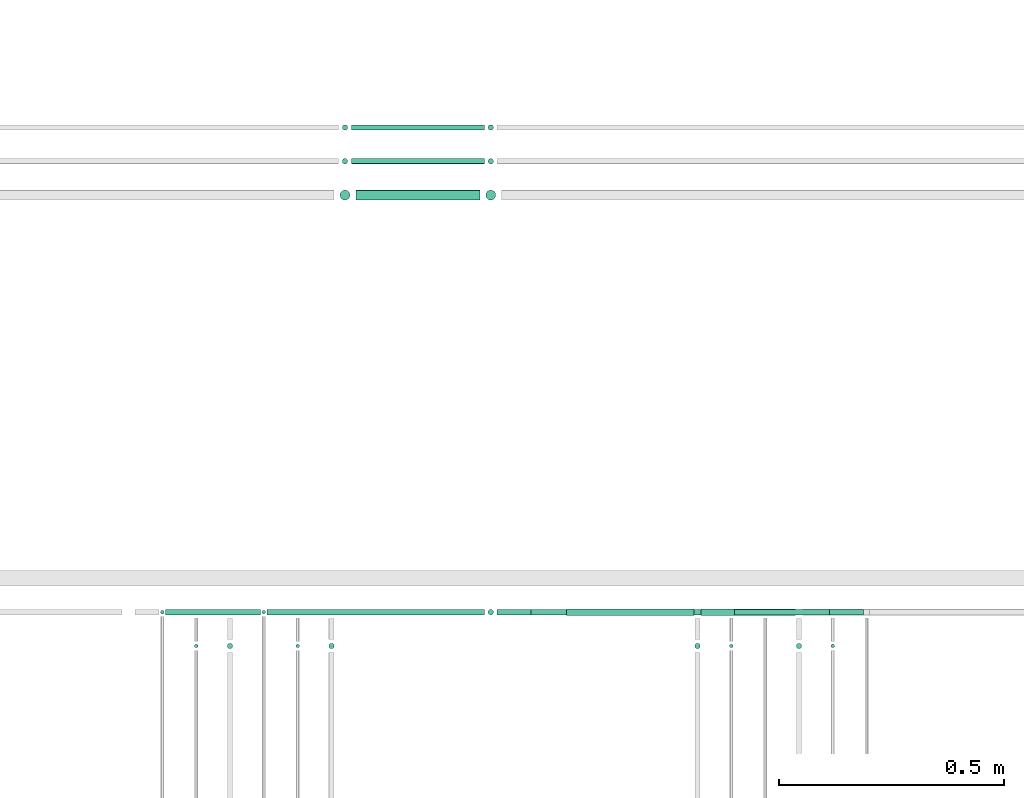
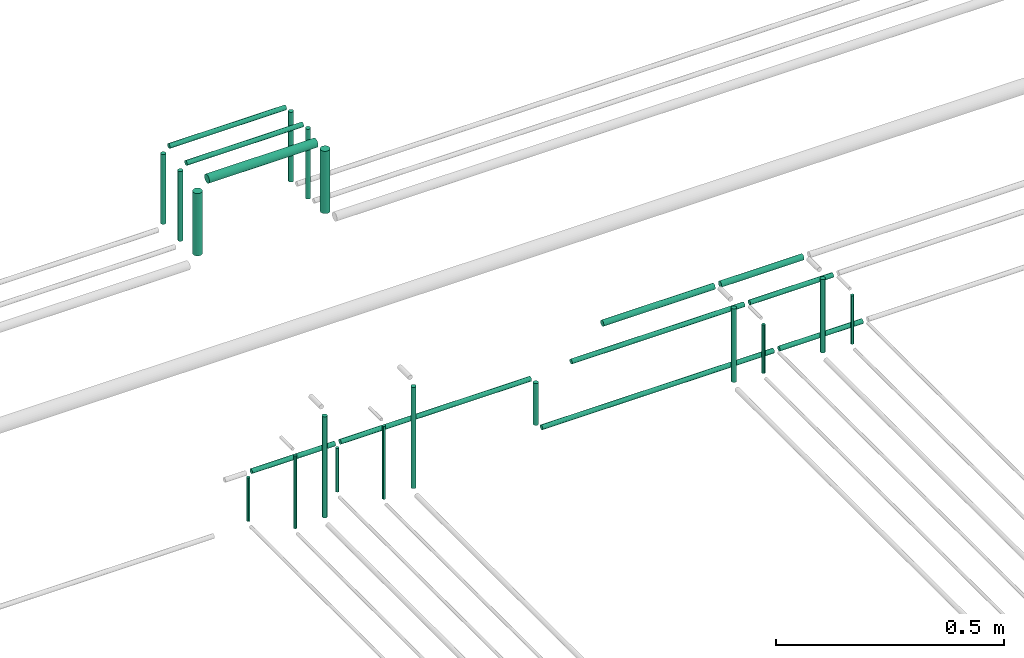
# One storey, part 142 of 331: 28 flow segments.
"""IFC2X3 building model written with IfcOpenShell, lengths in millimetres."""

from ifc_helpers import new_model, entity, si_unit, converted_unit, derived_unit, direction, frame, frame_2d, origin, origin_2d_with_axis, place, context, subcontext, project, spatial, circle, extrude, type_object, element, save


model = new_model("IFC2X3")

# Units and contexts
model_context = context("Model", 3, precision=0.01, world=origin(), true_north=direction((6.12303176911189e-17, 1.0)))
body_context = subcontext(model_context, "Body", "Model", "MODEL_VIEW")
ifc_project = project(units=[si_unit("LENGTHUNIT", "METRE", prefix="MILLI"), si_unit("AREAUNIT", "SQUARE_METRE"), si_unit("VOLUMEUNIT", "CUBIC_METRE"), converted_unit("PLANEANGLEUNIT", "DEGREE", entity("IfcRatioMeasure", 0.0174532925199433), si_unit("PLANEANGLEUNIT", "RADIAN"), dimensions=[0, 0, 0, 0, 0, 0, 0]), si_unit("MASSUNIT", "GRAM", prefix="KILO"), derived_unit("MASSDENSITYUNIT", [(si_unit("MASSUNIT", "GRAM", prefix="KILO"), 1), (si_unit("LENGTHUNIT", "METRE"), -3)]), derived_unit("MOMENTOFINERTIAUNIT", [(si_unit("LENGTHUNIT", "METRE"), 4)]), si_unit("TIMEUNIT", "SECOND"), si_unit("FREQUENCYUNIT", "HERTZ"), si_unit("THERMODYNAMICTEMPERATUREUNIT", "DEGREE_CELSIUS"), derived_unit("THERMALTRANSMITTANCEUNIT", [(si_unit("MASSUNIT", "GRAM", prefix="KILO"), 1), (si_unit("THERMODYNAMICTEMPERATUREUNIT", "KELVIN"), -1), (si_unit("TIMEUNIT", "SECOND"), -3)]), derived_unit("VOLUMETRICFLOWRATEUNIT", [(si_unit("LENGTHUNIT", "METRE"), 3), (si_unit("TIMEUNIT", "SECOND"), -1)]), derived_unit("MASSFLOWRATEUNIT", [(si_unit("MASSUNIT", "GRAM", prefix="KILO"), 1), (si_unit("TIMEUNIT", "SECOND"), -1)]), derived_unit("ROTATIONALFREQUENCYUNIT", [(si_unit("TIMEUNIT", "SECOND"), -1)]), si_unit("ELECTRICCURRENTUNIT", "AMPERE"), si_unit("ELECTRICVOLTAGEUNIT", "VOLT"), si_unit("POWERUNIT", "WATT"), si_unit("FORCEUNIT", "NEWTON", prefix="KILO"), si_unit("ILLUMINANCEUNIT", "LUX"), si_unit("LUMINOUSFLUXUNIT", "LUMEN"), si_unit("LUMINOUSINTENSITYUNIT", "CANDELA"), derived_unit("USERDEFINED", [(si_unit("MASSUNIT", "GRAM", prefix="KILO"), -1), (si_unit("LENGTHUNIT", "METRE"), -2), (si_unit("TIMEUNIT", "SECOND"), 3), (si_unit("LUMINOUSFLUXUNIT", "LUMEN"), 1)]), derived_unit("LINEARVELOCITYUNIT", [(si_unit("LENGTHUNIT", "METRE"), 1), (si_unit("TIMEUNIT", "SECOND"), -1)]), si_unit("PRESSUREUNIT", "PASCAL"), derived_unit("USERDEFINED", [(si_unit("LENGTHUNIT", "METRE"), -2), (si_unit("MASSUNIT", "GRAM", prefix="KILO"), 1), (si_unit("TIMEUNIT", "SECOND"), -2)]), derived_unit("LINEARFORCEUNIT", [(si_unit("MASSUNIT", "GRAM", prefix="KILO"), 1), (si_unit("LENGTHUNIT", "METRE"), 1), (si_unit("TIMEUNIT", "SECOND"), -2), (si_unit("LENGTHUNIT", "METRE"), -1)]), derived_unit("PLANARFORCEUNIT", [(si_unit("MASSUNIT", "GRAM", prefix="KILO"), 1), (si_unit("LENGTHUNIT", "METRE"), 1), (si_unit("TIMEUNIT", "SECOND"), -2), (si_unit("LENGTHUNIT", "METRE"), -2)])], contexts=[model_context])

# Site, building, storey
site_placement = place(None, frame((0.0, -0.00077364408347762, 0.0)))
site = spatial("IfcSite", under=ifc_project, at=site_placement, CompositionType="ELEMENT")
building_placement = place(site_placement, origin())
building = spatial("IfcBuilding", under=site, at=building_placement, CompositionType="ELEMENT")
storey_placement = place(building_placement, origin())
storey = spatial("IfcBuildingStorey", under=building, at=storey_placement, CompositionType="ELEMENT", Elevation=0.0)

# Flow segments
pipe_segment_type = type_object("IfcPipeSegmentType", PredefinedType="NOTDEFINED")
flow_segment_1_placement = place(storey_placement, frame((25651.7389068927, 9267.40472776412, 18442.4047277641)))
element("IfcFlowSegment", 1, at=flow_segment_1_placement, inside=storey, type_object=pipe_segment_type, context=body_context, shape_type="SweptSolid", body=[
    extrude(circle(Radius=6.0, at=frame_2d((-2.05744754566695e-11, 0.0), x_axis=(1.0, 0.0))), frame((0.0, 7.59527223593619, 7.5952722359167), z_axis=(1.0, 0.0, 0.0), x_axis=(0.0, 1.0, 0.0)), (0.0, 0.0, 1.0), 587.590020701265),
])
flow_segment_2_placement = place(storey_placement, frame((25051.7436346567, 9192.40472776411, 18464.0)))
element("IfcFlowSegment", 2, at=flow_segment_2_placement, inside=storey, type_object=pipe_segment_type, context=body_context, shape_type="SweptSolid", body=[
    extrude(circle(Radius=6.0, at=origin_2d_with_axis()), frame((7.59527223591454, 7.59527223591562, 0.0)), (0.0, 0.0, 1.0), 271.123247988028),
])
flow_segment_3_placement = place(storey_placement, frame((25276.7436346567, 9192.40472776411, 18464.0)))
element("IfcFlowSegment", 3, at=flow_segment_3_placement, inside=storey, type_object=pipe_segment_type, context=body_context, shape_type="SweptSolid", body=[
    extrude(circle(Radius=6.0, at=origin_2d_with_axis()), frame((7.59527223591454, 7.59527223591562, 0.0)), (0.0, 0.0, 1.0), 271.123247988039),
])
flow_segment_4_placement = place(storey_placement, frame((25805.7389068927, 9265.90472776418, 18665.9047277642)))
element("IfcFlowSegment", 4, at=flow_segment_4_placement, inside=storey, type_object=pipe_segment_type, context=body_context, shape_type="SweptSolid", body=[
    extrude(circle(Radius=7.5, at=frame_2d((-4.33146851719357e-12, 0.0), x_axis=(1.0, 0.0))), frame((0.0, 9.09527223591961, 9.09527223591636), z_axis=(1.0, 0.0, 0.0), x_axis=(0.0, 1.0, 0.0)), (0.0, 0.0, 1.0), 282.590020701257),
])
flow_segment_5_placement = place(storey_placement, frame((25630.1436346568, 9267.40472776416, 18464.0)))
element("IfcFlowSegment", 5, at=flow_segment_5_placement, inside=storey, type_object=pipe_segment_type, context=body_context, shape_type="SweptSolid", body=[
    extrude(circle(Radius=6.0, at=frame_2d((0.0, 1.08286712929839e-12), x_axis=(1.0, 0.0))), frame((7.59527223591454, 7.59527223591454, 0.0)), (0.0, 0.0, 1.0), 112.000000000003),
])
flow_segment_6_placement = place(storey_placement, frame((26253.328927594, 9267.40472776411, 18442.4047277641)))
element("IfcFlowSegment", 6, at=flow_segment_6_placement, inside=storey, type_object=pipe_segment_type, context=body_context, shape_type="SweptSolid", body=[
    extrude(circle(Radius=6.0, at=origin_2d_with_axis()), frame((0.0, 7.5952722359167, 7.5952722359167), z_axis=(1.0, 0.0, 0.0), x_axis=(0.0, 1.0, 0.0)), (0.0, 0.0, 1.0), 210.999999999991),
])
flow_segment_7_placement = place(storey_placement, frame((25128.7436346567, 9269.40472776415, 18460.0)))
element("IfcFlowSegment", 7, at=flow_segment_7_placement, inside=storey, type_object=pipe_segment_type, context=body_context, shape_type="SweptSolid", body=[
    extrude(circle(Radius=4.0, at=origin_2d_with_axis()), frame((5.59527223591499, 5.59527223591607, 0.0)), (0.0, 0.0, 1.0), 117.000000000041),
])
flow_segment_8_placement = place(storey_placement, frame((25141.3389068926, 9267.40472776415, 18582.4047277634)))
element("IfcFlowSegment", 8, at=flow_segment_8_placement, inside=storey, type_object=pipe_segment_type, context=body_context, shape_type="SweptSolid", body=[
    extrude(circle(Radius=6.0, at=frame_2d((1.08286712929839e-12, 0.0), x_axis=(1.0, 0.0))), frame((0.0, 7.59527223591562, 7.5952722359167), z_axis=(1.0, 0.0, 0.0), x_axis=(0.0, 1.0, 0.0)), (0.0, 0.0, 1.0), 482.400000000072),
])
flow_segment_9_placement = place(storey_placement, frame((24903.7436346567, 9269.40472776416, 18460.0)))
element("IfcFlowSegment", 9, at=flow_segment_9_placement, inside=storey, type_object=pipe_segment_type, context=body_context, shape_type="SweptSolid", body=[
    extrude(circle(Radius=4.0, at=origin_2d_with_axis()), frame((5.59527223591499, 5.59527223591607, 0.0)), (0.0, 0.0, 1.0), 117.00000000003),
])
flow_segment_10_placement = place(storey_placement, frame((26390.733655358, 9194.40472776412, 18460.0)))
element("IfcFlowSegment", 10, at=flow_segment_10_placement, inside=storey, type_object=pipe_segment_type, context=body_context, shape_type="SweptSolid", body=[
    extrude(circle(Radius=4.0, at=frame_2d((0.0, -1.08286712929839e-12), x_axis=(1.0, 0.0))), frame((5.59527223591499, 5.59527223591499, 0.0), z_axis=(0.0, 0.0, 1.0), x_axis=(-1.0, 0.0, 0.0)), (0.0, 0.0, 1.0), 130.000000000016),
])
flow_segment_11_placement = place(storey_placement, frame((26313.733655358, 9192.40472776411, 18464.0)))
element("IfcFlowSegment", 11, at=flow_segment_11_placement, inside=storey, type_object=pipe_segment_type, context=body_context, shape_type="SweptSolid", body=[
    extrude(circle(Radius=6.0, at=origin_2d_with_axis()), frame((7.59527223591454, 7.59527223591562, 0.0)), (0.0, 0.0, 1.0), 196.999999999886),
])
flow_segment_12_placement = place(storey_placement, frame((26165.733655358, 9194.40472776413, 18460.0)))
element("IfcFlowSegment", 12, at=flow_segment_12_placement, inside=storey, type_object=pipe_segment_type, context=body_context, shape_type="SweptSolid", body=[
    extrude(circle(Radius=4.0, at=origin_2d_with_axis()), frame((5.59527223591499, 5.59527223591607, 0.0)), (0.0, 0.0, 1.0), 129.999999999899),
])
flow_segment_13_placement = place(storey_placement, frame((26088.733655358, 9192.40472776411, 18464.0)))
element("IfcFlowSegment", 13, at=flow_segment_13_placement, inside=storey, type_object=pipe_segment_type, context=body_context, shape_type="SweptSolid", body=[
    extrude(circle(Radius=6.0, at=origin_2d_with_axis()), frame((7.59527223591454, 7.59527223591562, 0.0)), (0.0, 0.0, 1.0), 196.999999999979),
])
flow_segment_14_placement = place(storey_placement, frame((25328.3389068926, 10342.430236278, 18657.404727764)))
element("IfcFlowSegment", 14, at=flow_segment_14_placement, inside=storey, type_object=pipe_segment_type, context=body_context, shape_type="SweptSolid", body=[
    extrude(circle(Radius=6.0, at=origin_2d_with_axis()), frame((0.0, 7.5952722359167, 7.5952722359167), z_axis=(1.0, 0.0, 0.0), x_axis=(0.0, 1.0, 0.0)), (0.0, 0.0, 1.0), 295.400000000093),
])
flow_segment_15_placement = place(building_placement, frame((25306.7436346567, 10342.430236278, 18464.0)))
element("IfcFlowSegment", 15, at=flow_segment_15_placement, inside=storey, type_object=pipe_segment_type, context=body_context, shape_type="SweptSolid", body=[
    extrude(circle(Radius=6.0, at=origin_2d_with_axis()), frame((7.59527223591454, 7.5952722359167, 0.0), z_axis=(0.0, 0.0, 1.0), x_axis=(-1.0, 0.0, 0.0)), (0.0, 0.0, 1.0), 187.000000000001),
])
flow_segment_16_placement = place(building_placement, frame((25630.1436346568, 10342.430236278, 18464.0)))
element("IfcFlowSegment", 16, at=flow_segment_16_placement, inside=storey, type_object=pipe_segment_type, context=body_context, shape_type="SweptSolid", body=[
    extrude(circle(Radius=6.0, at=origin_2d_with_axis()), frame((7.59527223591454, 7.5952722359167, 0.0)), (0.0, 0.0, 1.0), 186.999999999975),
])
flow_segment_17_placement = place(storey_placement, frame((25328.3389068926, 10267.430236278, 18657.4047277641)))
element("IfcFlowSegment", 17, at=flow_segment_17_placement, inside=storey, type_object=pipe_segment_type, context=body_context, shape_type="SweptSolid", body=[
    extrude(circle(Radius=6.0, at=origin_2d_with_axis()), frame((0.0, 7.5952722359167, 7.5952722359167), z_axis=(1.0, 0.0, 0.0), x_axis=(0.0, 1.0, 0.0)), (0.0, 0.0, 1.0), 295.400000000097),
])
flow_segment_18_placement = place(storey_placement, frame((25630.1436346568, 10267.430236278, 18464.0)))
element("IfcFlowSegment", 18, at=flow_segment_18_placement, inside=storey, type_object=pipe_segment_type, context=body_context, shape_type="SweptSolid", body=[
    extrude(circle(Radius=6.0, at=origin_2d_with_axis()), frame((7.59527223591454, 7.5952722359167, 0.0)), (0.0, 0.0, 1.0), 186.999999999983),
])
flow_segment_19_placement = place(storey_placement, frame((25306.7436346567, 10267.430236278, 18464.0)))
element("IfcFlowSegment", 19, at=flow_segment_19_placement, inside=storey, type_object=pipe_segment_type, context=body_context, shape_type="SweptSolid", body=[
    extrude(circle(Radius=6.0, at=origin_2d_with_axis()), frame((7.59527223591454, 7.5952722359167, 0.0)), (0.0, 0.0, 1.0), 187.000000000033),
])
flow_segment_20_placement = place(storey_placement, frame((25338.3389068926, 10187.430236278, 18652.4047277641)))
element("IfcFlowSegment", 20, at=flow_segment_20_placement, inside=storey, type_object=pipe_segment_type, context=body_context, shape_type="SweptSolid", body=[
    extrude(circle(Radius=11.0, at=frame_2d((-2.16573425859679e-12, 0.0), x_axis=(1.0, 0.0))), frame((0.0, 12.5952722359177, 12.5952722359156), z_axis=(1.0, 0.0, 0.0), x_axis=(0.0, 1.0, 0.0)), (0.0, 0.0, 1.0), 275.400000000102),
])
flow_segment_21_placement = place(storey_placement, frame((25625.1436346568, 10187.430236278, 18474.0)))
element("IfcFlowSegment", 21, at=flow_segment_21_placement, inside=storey, type_object=pipe_segment_type, context=body_context, shape_type="SweptSolid", body=[
    extrude(circle(Radius=11.0, at=origin_2d_with_axis()), frame((12.5952722359177, 12.5952722359156, 0.0)), (0.0, 0.0, 1.0), 166.999999999984),
])
flow_segment_22_placement = place(storey_placement, frame((25301.7436346567, 10187.430236278, 18474.0)))
element("IfcFlowSegment", 22, at=flow_segment_22_placement, inside=storey, type_object=pipe_segment_type, context=body_context, shape_type="SweptSolid", body=[
    extrude(circle(Radius=11.0, at=frame_2d((0.0, -2.16573425859679e-12), x_axis=(1.0, 0.0))), frame((12.5952722359177, 12.5952722359177, 0.0)), (0.0, 0.0, 1.0), 167.000000000034),
])
flow_segment_23_placement = place(storey_placement, frame((24978.7436346567, 9194.4047277641, 18460.0)))
element("IfcFlowSegment", 23, at=flow_segment_23_placement, inside=storey, type_object=pipe_segment_type, context=body_context, shape_type="SweptSolid", body=[
    extrude(circle(Radius=4.0, at=origin_2d_with_axis()), frame((5.59527223591499, 5.59527223591607, 0.0)), (0.0, 0.0, 1.0), 195.000000000036),
])
flow_segment_24_placement = place(storey_placement, frame((25203.7436346567, 9194.4047277641, 18460.0)))
element("IfcFlowSegment", 24, at=flow_segment_24_placement, inside=storey, type_object=pipe_segment_type, context=body_context, shape_type="SweptSolid", body=[
    extrude(circle(Radius=4.0, at=origin_2d_with_axis()), frame((5.59527223591499, 5.59527223591607, 0.0)), (0.0, 0.0, 1.0), 195.000000000031),
])
flow_segment_25_placement = place(storey_placement, frame((26178.328927594, 9267.40472776415, 18592.404727764)))
element("IfcFlowSegment", 25, at=flow_segment_25_placement, inside=storey, type_object=pipe_segment_type, context=body_context, shape_type="SweptSolid", body=[
    extrude(circle(Radius=6.0, at=origin_2d_with_axis()), frame((0.0, 7.59527223591562, 7.5952722359167), z_axis=(1.0, 0.0, 0.0), x_axis=(0.0, -1.0, 0.0)), (0.0, 0.0, 1.0), 211.000000000013),
])
flow_segment_26_placement = place(storey_placement, frame((26104.328927594, 9265.90472776418, 18665.9047277641)))
element("IfcFlowSegment", 26, at=flow_segment_26_placement, inside=storey, type_object=pipe_segment_type, context=body_context, shape_type="SweptSolid", body=[
    extrude(circle(Radius=7.5, at=frame_2d((4.33146851719357e-12, 0.0), x_axis=(1.0, 0.0))), frame((0.0, 9.09527223592069, 9.09527223591636), z_axis=(1.0, 0.0, 0.0), x_axis=(0.0, 1.0, 0.0)), (0.0, 0.0, 1.0), 208.999999999952),
])
flow_segment_27_placement = place(storey_placement, frame((25726.7389068927, 9267.40472776415, 18592.404727764)))
element("IfcFlowSegment", 27, at=flow_segment_27_placement, inside=storey, type_object=pipe_segment_type, context=body_context, shape_type="SweptSolid", body=[
    extrude(circle(Radius=6.0, at=frame_2d((-2.16573425859679e-12, 0.0), x_axis=(1.0, 0.0))), frame((0.0, 7.59527223591778, 7.5952722359167), z_axis=(1.0, 0.0, 0.0), x_axis=(0.0, 1.0, 0.0)), (0.0, 0.0, 1.0), 437.590020701265),
])
flow_segment_28_placement = place(storey_placement, frame((24916.3389068926, 9267.40472776415, 18582.4047277641)))
element("IfcFlowSegment", 28, at=flow_segment_28_placement, inside=storey, type_object=pipe_segment_type, context=body_context, shape_type="SweptSolid", body=[
    extrude(circle(Radius=6.0, at=frame_2d((-2.16573425859679e-12, 0.0), x_axis=(1.0, 0.0))), frame((0.0, 7.59527223591778, 7.5952722359167), z_axis=(1.0, 0.0, 0.0), x_axis=(0.0, 1.0, 0.0)), (0.0, 0.0, 1.0), 210.999999999995),
])

save(model, "model.ifc")
